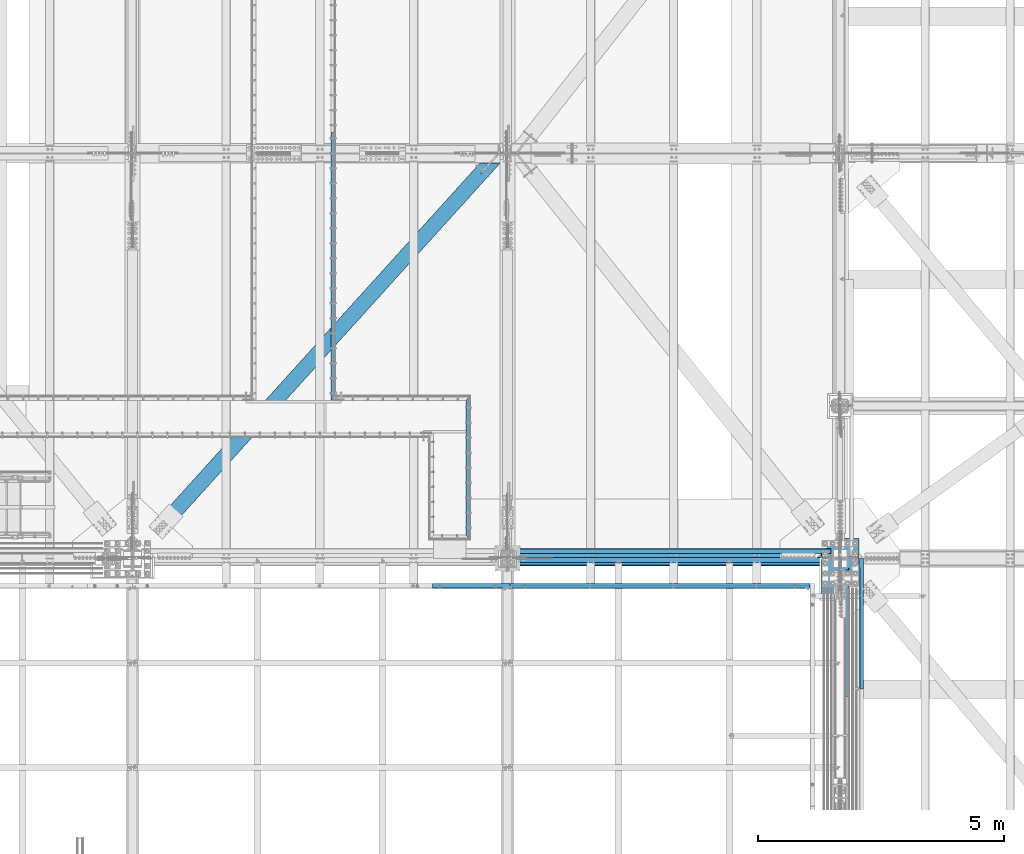
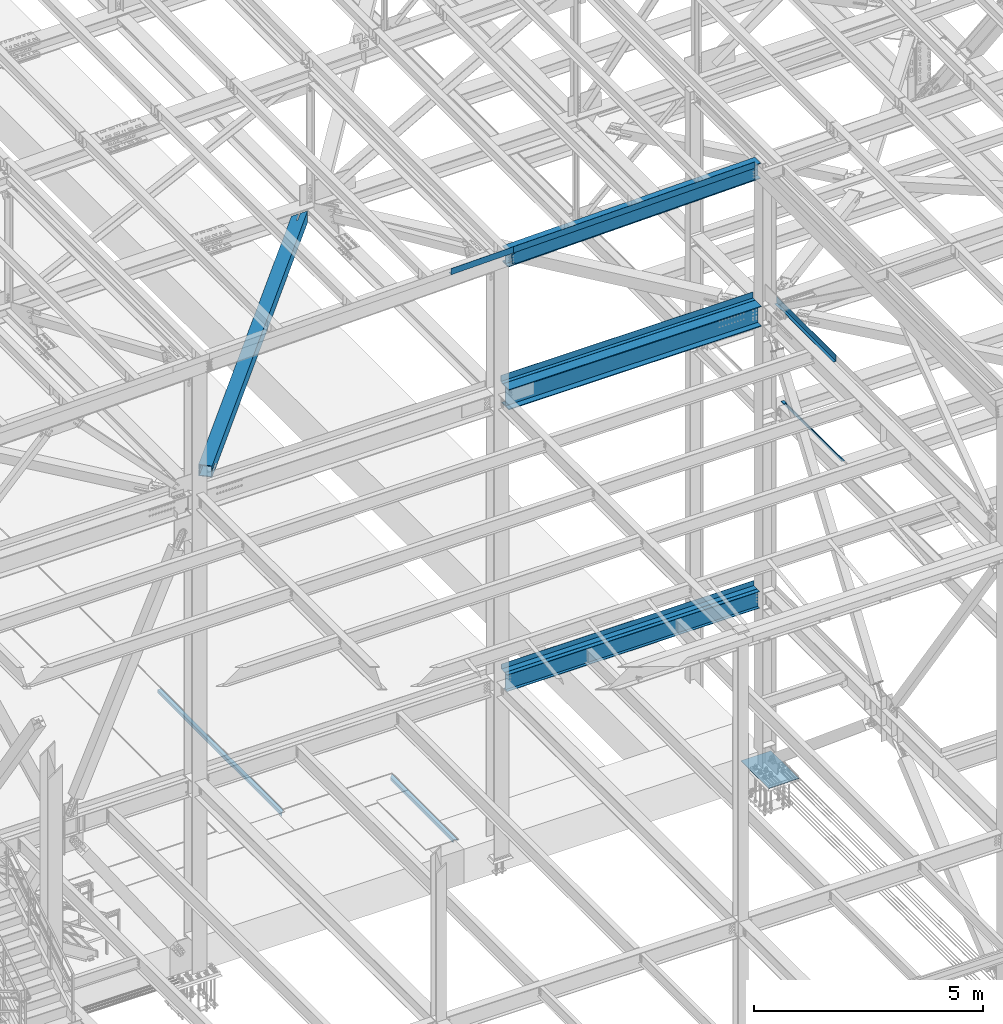
# One storey, part 1800 of 3843: 14 beams, 12 elements without a shape of their own.
"""IFC2X3 building model written with IfcOpenShell, lengths in millimetres."""

from ifc_helpers import new_model, si_unit, frame, origin_with_axes, place, context, subcontext, project, spatial, faceted_brep, material, type_object, element, aggregate, save


model = new_model("IFC2X3")

# Units and contexts
model_context = context("Model", 3, precision=1e-05, world=origin_with_axes())
body_context = subcontext(model_context, "Body", "Model", "MODEL_VIEW")
ifc_project = project(units=[si_unit("LENGTHUNIT", "METRE", prefix="MILLI"), si_unit("AREAUNIT", "SQUARE_METRE"), si_unit("VOLUMEUNIT", "CUBIC_METRE"), si_unit("MASSUNIT", "GRAM", prefix="KILO"), si_unit("TIMEUNIT", "SECOND"), si_unit("PLANEANGLEUNIT", "RADIAN"), si_unit("SOLIDANGLEUNIT", "STERADIAN"), si_unit("THERMODYNAMICTEMPERATUREUNIT", "DEGREE_CELSIUS"), si_unit("LUMINOUSINTENSITYUNIT", "LUMEN")], contexts=[model_context])

# Site, building, storey
site_placement = place(None, origin_with_axes())
site = spatial("IfcSite", under=ifc_project, at=site_placement, CompositionType="ELEMENT")
building_placement = place(site_placement, origin_with_axes())
building = spatial("IfcBuilding", under=site, at=building_placement, Name="Undefined", CompositionType="ELEMENT")
storey_placement = place(building_placement, origin_with_axes())
storey = spatial("IfcBuildingStorey", under=building, at=storey_placement, Name="Undefined", CompositionType="ELEMENT", Elevation=0.0)

# Assembly, beam
assembly_1_placement = place(storey_placement, origin_with_axes())
assembly_1 = element("IfcElementAssembly", 1, at=assembly_1_placement, inside=storey, Name="EMBED_ANGLE", AssemblyPlace="NOTDEFINED", PredefinedType="RIGID_FRAME")
ifc_material_1 = material(Name="STEEL/A36")
beam_type_1 = type_object("IfcBeamType", Name="L3-1/2X3-1/2X5/16", PredefinedType="NOTDEFINED")
beam_1_placement = place(assembly_1_placement, frame((69457.0619228334, 26000.0750033204, 30410.15), z_axis=(1.0, 0.0, 0.0), x_axis=(0.0, 1.0, 0.0)))
beam_1 = element("IfcBeam", 2, at=beam_1_placement, type_object=beam_type_1, material=ifc_material_1, Name="EMBED_ANGLE", ObjectType="L3-1/2X3-1/2X5/16", context=body_context, shape_type="Brep", body=[
    faceted_brep([(88.8999999971129, 44.4500000000007, -44.4499999999971), (-3.63797880709171e-12, 44.4499999999971, 44.4500000000007), (2917.82499712405, 44.4500000000007, 44.4499999917316), (2828.92499622636, 44.4500000000007, -44.4500000080152), (-3.63797880709171e-12, 36.5124999999971, 44.4500000000007), (2917.82499712405, 36.5125000000007, 44.4499999917316), (80.9624999971129, 36.5125000000007, -36.5124999999971), (2836.86249630651, 36.5125000000007, -36.5125000080443), (80.9624999971129, -44.4500000000007, -36.5124999999971), (2836.86249630651, -44.4500000000007, -36.5125000080443), (88.8999999971129, -44.4500000000007, -44.4499999999971), (2828.92499622636, -44.4500000000007, -44.4500000080152)], [[[0, 1, 2, 3]], [[1, 4, 5, 2]], [[4, 6, 7, 5]], [[6, 8, 9, 7]], [[8, 10, 11, 9]], [[10, 0, 3, 11]], [[5, 7, 9, 11, 3, 2]], [[10, 8, 6, 4, 1, 0]]]),
])
aggregate(assembly_1, [beam_1])

assembly_2_placement = place(storey_placement, origin_with_axes())
assembly_2 = element("IfcElementAssembly", 3, at=assembly_2_placement, inside=storey, Name="EMBED_ANGLE", AssemblyPlace="NOTDEFINED", PredefinedType="RIGID_FRAME")
beam_2_placement = place(assembly_2_placement, frame((66713.862, 34264.6001953125, 30410.15), z_axis=(0.0, 0.0, -1.0), x_axis=(0.0, -1.0, 0.0)))
beam_2 = element("IfcBeam", 4, at=beam_2_placement, type_object=beam_type_1, material=ifc_material_1, Name="EMBED_ANGLE", ObjectType="L3-1/2X3-1/2X5/16", context=body_context, shape_type="Brep", body=[
    faceted_brep([(-3.63797880709171e-12, 44.4499999999971, -44.4500000000007), (-3.63797880709171e-12, 44.4499999999971, 44.4500000000007), (5435.6001953125, 44.4499999999971, 44.4500000000007), (5435.6001953125, 44.4499999999971, -44.4500000000007), (-3.63797880709171e-12, 36.5124999999971, 44.4500000000007), (5427.6626953125, 36.5124999999971, 44.4500000000007), (-3.63797880709171e-12, 36.5124999999971, -36.5125000000007), (5427.6626953125, 36.5124999999971, -36.5125000000007), (3.63797880709171e-12, -44.4499999999971, -36.5125000000007), (5346.70019531249, -44.4499999999971, -36.5125000000007), (3.63797880709171e-12, -44.4499999999971, -44.4500000000007), (5346.70019531249, -44.4499999999971, -44.4500000000007)], [[[0, 1, 2, 3]], [[1, 4, 5, 2]], [[4, 6, 7, 5]], [[6, 8, 9, 7]], [[8, 10, 11, 9]], [[10, 0, 3, 11]], [[5, 7, 9, 11, 3, 2]], [[10, 8, 6, 4, 1, 0]]]),
])
aggregate(assembly_2, [beam_2])

# Assembly, beams
assembly_3_placement = place(storey_placement, origin_with_axes())
assembly_3 = element("IfcElementAssembly", 5, at=assembly_3_placement, inside=storey, Name="BEAM", AssemblyPlace="NOTDEFINED", PredefinedType="RIGID_FRAME")
ifc_material_2 = material(Name="STEEL/A572-50")
beam_type_2 = type_object("IfcBeamType", Name="C12X20.7", PredefinedType="NOTDEFINED")
beam_3_placement = place(assembly_3_placement, frame((70253.0420932875, 25044.4000000661, 46289.660029082), z_axis=(0.0211520550054438, 0.0, -0.999776270257025), x_axis=(0.999776270257024, 0.0, 0.0211520550054619)))
beam_3 = element("IfcBeam", 6, at=beam_3_placement, type_object=beam_type_2, material=ifc_material_2, Name="BEAM", ObjectType="C12X20.7", context=body_context, shape_type="Brep", body=[
    faceted_brep([(6142.0584947462, -38.1000000000058, 146.047460004978), (6142.0584947462, -38.1000000000058, 152.400000004971), (98.4250003414782, -38.1000000000058, 152.399999999863), (98.4250003414927, -38.1000000000058, 146.047459999871), (6142.0584947462, 38.1000000000058, 152.400000004971), (98.4250003414782, 38.1000000000058, 152.399999999863), (85.7250005323076, 30.1625000000058, 126.99999997508), (85.7250005323076, 38.1000000000058, 126.99999997508), (15.8750006201954, 38.1000000000058, 126.999999975014), (15.8753301115794, 30.1625000000058, 127.000000030457), (90.5850800503176, 30.1625000000058, 127.966729897671), (90.5850800503176, 38.1000000000058, 127.966729897671), (94.7052565184495, 30.1625000000058, 130.719743798138), (94.7052565184495, 38.1000000000058, 130.719743798138), (97.4582704189161, 30.1625000000058, 134.674927499887), (97.4582704189233, 38.1000000000058, 134.839920266269), (98.4250003414927, 1.29402906168252e-06, 139.699999784301), (98.4250003414927, 38.1000000000058, 139.699999784301), (6142.05849474619, 30.1625000000058, 134.674927505002), (6142.05849466294, 30.1624999999985, 116.299999962248), (6142.0584946629, 30.1624999999985, -114.300000034018), (6142.05849474625, 30.1625000000058, -134.674927494561), (6142.05849474623, -38.1000000000058, -146.047459994552), (6142.05849474625, -38.1000000000058, -152.399999994537), (6142.05849474625, 38.1000000000058, -152.399999994537), (98.4250003417837, -38.1000000000058, -152.399999999638), (98.4250003417837, 38.1000000000058, -152.399999999638), (94.7052565187187, 38.1000000000058, -130.719743846734), (90.5850800505723, 38.1000000000058, -127.966729946267), (85.725000532555, 38.1000000000058, -127.000000023691), (15.8750003662499, 38.1000000000058, -127.000000023749), (98.4250003417692, 38.1000000000058, -139.699999832876), (97.4582704191853, 38.1000000000058, -134.839920314858), (15.8753294955532, 30.1624999999985, -114.300001144882), (15.8753211909934, 30.1624999999985, 116.299998852854), (15.8753209642891, 30.1625000000058, -126.999999968277), (85.725000532555, 30.1625000000058, -127.000000023691), (90.5850800505723, 30.1625000000058, -127.966729946267), (94.7052565187187, 30.1625000000058, -130.719743846734), (97.458270419178, 30.1625000000058, -134.674927499669), (98.4250003417692, 1.00112811196595e-06, -139.699999832876), (98.4250003417765, -38.1000000000058, -146.047459999652)], [[[0, 1, 2, 3]], [[1, 4, 5, 2]], [[6, 7, 8, 9]], [[10, 11, 7, 6]], [[12, 13, 11, 10]], [[14, 15, 13, 12]], [[16, 17, 15, 14]], [[2, 5, 17, 16, 3]], [[14, 18, 0, 3, 16]], [[1, 0, 18, 19, 20, 21, 22, 23, 24, 4]], [[24, 23, 25, 26]], [[27, 28, 29, 30, 8, 7, 11, 13, 15, 17, 5, 4, 24, 26, 31, 32]], [[33, 34, 9, 8, 30, 35]], [[21, 20, 19, 18, 14, 12, 10, 6, 9, 34, 33, 35, 36, 37, 38, 39]], [[22, 21, 39, 40, 41]], [[23, 22, 41, 25]], [[40, 31, 26, 25, 41]], [[39, 32, 31, 40]], [[38, 27, 32, 39]], [[37, 28, 27, 38]], [[36, 29, 28, 37]], [[35, 30, 29, 36]]]),
])
beam_type_3 = type_object("IfcBeamType", PredefinedType="NOTDEFINED")
beam_4_placement = place(assembly_3_placement, frame((73356.2395281099, 25107.8999997327, 46510.9236615388), z_axis=(0.999776270257024, 0.0, 0.0211520550054619), x_axis=(0.0, -1.0, 0.0)))
beam_4 = element("IfcBeam", 7, at=beam_4_placement, type_object=beam_type_3, material=ifc_material_1, Name="BENT_PLATE", context=body_context, shape_type="Brep", body=[
    faceted_brep([(-3.50355549016967e-07, -3.17499999742722, -3048.00000001723), (3.50421032635495e-07, -3.17500000260043, 3048.00000001724), (3.5035191103816e-07, 3.17499999739084, 3048.00000001724), (-3.50424670614302e-07, 3.17500000256405, -3048.00000001723), (101.599999864371, 3.17499999856227, 3048.00000000522), (101.599998739839, 3.17500000373548, -3048.00000002925), (95.249998765099, -3.17499999632128, -3048.00000002851), (95.2499998896274, -3.17500000149448, 3048.00000000597), (101.600000309205, -161.925000875126, 3047.9999999938), (101.599999608374, -161.925000446165, -3048.00000004067), (95.2500003092064, -161.925000900388, 3047.99999999456), (95.2499996083752, -161.925000471427, -3048.00000003992)], [[[0, 1, 2, 3]], [[3, 2, 4, 5]], [[1, 0, 6, 7]], [[5, 4, 8, 9]], [[4, 2, 1, 7, 10, 8]], [[7, 6, 11, 10]], [[6, 0, 3, 5, 9, 11]], [[10, 11, 9, 8]]]),
])
aggregate(assembly_3, [beam_3, beam_4])

# Assembly, beam
assembly_4_placement = place(storey_placement, origin_with_axes())
assembly_4 = element("IfcElementAssembly", 8, at=assembly_4_placement, inside=storey, Name="BEAM", AssemblyPlace="NOTDEFINED", PredefinedType="RIGID_FRAME")
beam_5_placement = place(assembly_4_placement, frame((69520.1104824226, 25107.8999985199, 46429.7633261585), z_axis=(0.999776270257024, 0.0, 0.0211520550054619), x_axis=(0.0, -1.0, 0.0)))
beam_5 = element("IfcBeam", 9, at=beam_5_placement, type_object=beam_type_3, material=ifc_material_1, Name="BENT_PLATE", context=body_context, shape_type="Brep", body=[
    faceted_brep([(1.80807546712458e-09, 2.85952410195023e-06, 788.98750000447), (1.83717929758132e-09, -3.17500000066502, 785.81249736427), (95.2499986975417, -3.17499999957363, 785.812497363717), (98.4249975161692, 2.86066642729566e-06, 788.987500003917), (95.2499993281599, -161.925001317926, 785.81249745957), (98.4249981594003, -161.925001305302, 788.987500003583), (-1.77533365786076e-09, -3.1749999993408, -785.812500061627), (-1.81535142473876e-09, -5.62722561880946e-08, -788.987500004456), (98.4249986264876, -5.5137206800282e-08, -788.987500005023), (95.2499986923067, -3.17499999824213, -785.812500062151), (98.424999271374, -161.925001302356, -788.987500005343), (95.2499993245401, -161.925001314979, -785.812500062311), (1.77533365786076e-09, 3.17499999931897, 788.987500004485), (-1.84809323400259e-09, 3.17500000065047, -788.987500004456), (101.599998672296, 3.17500000048312, 788.987500003903), (101.599998667039, 3.17500000182918, -788.987500005023), (101.599999328169, -161.925001292671, 788.987500003583), (101.599999324535, -161.925001289717, -788.987500005358)], [[[0, 1, 2, 3]], [[3, 2, 4, 5]], [[6, 7, 8, 9]], [[9, 8, 10, 11]], [[9, 11, 4, 2]], [[1, 0, 12, 13, 7, 6]], [[13, 12, 14, 15]], [[2, 1, 6, 9]], [[15, 14, 16, 17]], [[16, 14, 12, 0, 3, 5]], [[7, 13, 15, 17, 10, 8]], [[11, 10, 17, 16, 5, 4]]]),
])
aggregate(assembly_4, [beam_5])

assembly_5_placement = place(storey_placement, origin_with_axes())
assembly_5 = element("IfcElementAssembly", 10, at=assembly_5_placement, inside=storey, Name="BEAM", AssemblyPlace="NOTDEFINED", PredefinedType="RIGID_FRAME")
ifc_material_3 = material(Name="STEEL/A992")
beam_type_4 = type_object("IfcBeamType", Name="W21X101", PredefinedType="NOTDEFINED")
beam_6_placement = place(assembly_5_placement, frame((70256.4, 25615.9, 42197.3375), z_axis=(0.0, 0.0, 1.0), x_axis=(1.0, 0.0, 0.0)))
beam_6 = element("IfcBeam", 11, at=beam_6_placement, type_object=beam_type_4, material=ifc_material_3, Name="BEAM", ObjectType="W21X101", context=body_context, shape_type="Brep", body=[
    faceted_brep([(196.850000000006, -155.575000000001, -271.462500000001), (196.850000000006, 155.575000000001, -271.462500000001), (6565.89999999999, 155.575000000001, -271.462500000001), (6565.89999999999, -155.575000000001, -271.462500000001), (196.850000000006, -155.575000000001, -250.824999999997), (196.850000000006, -6.34999999999854, -250.824999999997), (196.850000000006, -6.34999999999854, 250.824999999997), (196.850000000006, -155.575000000001, 250.824999999997), (196.850000000006, -155.575000000001, 271.462500000001), (196.850000000006, 155.575000000001, 271.462500000001), (196.850000000006, 155.575000000001, 250.824999999997), (196.850000000006, 6.34999999999854, 250.824999999997), (196.850000000006, 6.34999999999854, -250.824999999997), (196.850000000006, 155.575000000001, -250.824999999997), (6565.89999999999, -155.575000000001, -250.824999999997), (6565.89999999999, -6.34999999999854, -250.824999999997), (6565.89999999999, -6.34999999999854, 250.824999999997), (6565.89999999999, -155.575000000001, 250.824999999997), (6565.89999999999, -155.575000000001, 271.462500000001), (6565.89999999999, 155.575000000001, 271.462500000001), (6565.89999999999, 155.575000000001, 250.824999999997), (6565.89999999999, 6.34999999999854, 250.824999999997), (6565.89999999999, 6.34999999999854, -250.824999999997), (6565.89999999999, 155.575000000001, -250.824999999997)], [[[0, 1, 2, 3]], [[0, 4, 5, 6, 7, 8, 9, 10, 11, 12, 13, 1]], [[5, 4, 14, 15]], [[6, 5, 15, 16]], [[7, 6, 16, 17]], [[8, 7, 17, 18]], [[9, 8, 18, 19]], [[10, 9, 19, 20]], [[11, 10, 20, 21]], [[12, 11, 21, 22]], [[13, 12, 22, 23]], [[1, 13, 23, 2]], [[22, 21, 20, 19, 18, 17, 16, 15, 14, 3, 2, 23]], [[4, 0, 3, 14]]]),
])
aggregate(assembly_5, [beam_6])

assembly_6_placement = place(storey_placement, origin_with_axes())
assembly_6 = element("IfcElementAssembly", 12, at=assembly_6_placement, inside=storey, Name="BENT_PLATE", AssemblyPlace="NOTDEFINED", PredefinedType="RIGID_FRAME")
beam_type_5 = type_object("IfcBeamType", PredefinedType="NOTDEFINED")
beam_7_placement = place(assembly_6_placement, frame((77117.5749999996, 24118.094, 42471.975), z_axis=(0.0, -1.0, 0.0), x_axis=(1.0, 0.0, 0.0)))
beam_7 = element("IfcBeam", 13, at=beam_7_placement, type_object=beam_type_5, material=ifc_material_1, Name="BENT_PLATE", context=body_context, shape_type="Brep", body=[
    faceted_brep([(0.0, 3.17500000000291, 1300.95650004768), (0.0, 4.7679350245744e-08, 1304.1315), (69.8499999527558, 4.76647983305156e-08, 1304.1315), (66.6750000004104, 3.17499999998836, 1300.95650004768), (69.8499999527558, 161.924999999545, 1304.1315), (66.6750000004104, 161.924999999545, 1300.95650004768), (66.6750000004104, 161.924999999545, -1304.1315), (66.6750000004104, 3.17499999998836, -1304.1315), (66.6750000004104, 3.17499999998836, -1266.81639935417), (66.675000000454, -3.17500000001746, -1266.81639935417), (66.6750000004686, -3.17500000001746, -1304.1315), (0.0, -3.17500000000291, -1266.81639935416), (0.0, 3.17500000000291, -1266.81639935416), (9.52499997131235, -3.17500000000291, -990.599750006706), (9.52499997131235, 3.17499999999563, -990.599750006706), (0.0, 3.17500000000291, -990.599750003017), (0.0, -3.17500000000291, -990.599750003017), (9.5249999712978, -3.17500000000291, -673.099750006717), (9.5249999712978, 3.17499999999563, -673.099750006717), (0.0, -3.17500000000291, -673.099750006702), (0.0, 3.17500000000291, -673.099750006702), (0.0, -3.17500000000291, 1304.1315), (73.0250000004162, -3.17500000001746, 1304.1315), (73.0250000004162, 161.924999999545, 1304.1315), (73.0250000004162, -3.17500000001746, -1304.1315), (73.0250000004162, 161.924999999545, -1304.1315)], [[[0, 1, 2, 3]], [[3, 2, 4, 5]], [[6, 7, 8, 3, 5]], [[9, 8, 7, 10]], [[11, 12, 8, 9]], [[13, 14, 15, 16]], [[17, 18, 14, 13]], [[19, 20, 18, 17]], [[20, 19, 21, 1, 0]], [[1, 21, 22, 23, 4, 2]], [[22, 24, 25, 23]], [[6, 25, 24, 10, 7]], [[23, 25, 6, 5, 4]], [[8, 12, 15, 14, 18, 20, 0, 3]], [[16, 15, 12, 11]], [[24, 22, 21, 19, 17, 13, 16, 11, 9, 10]]]),
])
aggregate(assembly_6, [beam_7])

assembly_7_placement = place(storey_placement, origin_with_axes())
assembly_7 = element("IfcElementAssembly", 14, at=assembly_7_placement, inside=storey, Name="BENT_PLATE", AssemblyPlace="NOTDEFINED", PredefinedType="RIGID_FRAME")
beam_type_6 = type_object("IfcBeamType", PredefinedType="NOTDEFINED")
beam_8_placement = place(assembly_7_placement, frame((77484.2875000011, 24288.75, 39627.1750000005), z_axis=(0.0, 1.0, 0.0), x_axis=(-1.0, 0.0, 0.0)))
beam_8 = element("IfcBeam", 15, at=beam_8_placement, type_object=beam_type_6, material=ifc_material_1, Name="BENT_PLATE", context=body_context, shape_type="Brep", body=[
    faceted_brep([(73.0249999527732, -4.71118255518377e-08, -1327.15), (69.8500000010245, 3.17499999969004, -1323.97499999999), (69.8500000012136, 73.024999998619, -1323.97499999999), (73.025000001202, 73.0249999986117, -1327.15), (0.0, -4.74465196020901e-08, -1327.15), (1.45519152283669e-11, 3.17500000000291, -1323.97499999999), (1.45519152283669e-11, -3.17500000000291, 1327.15), (-1.45519152283669e-11, -3.17500000000291, -1327.15), (76.2000000010157, -3.17500000034488, -1327.15), (76.1999999999825, -3.1749999997628, 1327.14999999999), (-1.45519152283669e-11, 3.17500000000291, 1327.15), (76.1999999999243, 3.17500000035216, 1327.15), (69.8500000010245, 3.17499999969004, 1327.15), (76.2000000012195, 73.0249999986045, 1143.0), (69.8500000012136, 73.024999998619, 1143.0), (69.8500000010245, 3.17499999969004, 1143.0), (76.2000000010303, 3.17499999977008, 1143.0), (76.2000000012195, 73.0249999986045, -1327.15), (1.45519152283669e-11, 3.17499999999927, 1143.00000000001)], [[[0, 1, 2, 3]], [[4, 5, 1, 0]], [[6, 7, 8, 9]], [[10, 6, 9, 11, 12]], [[13, 14, 15, 16]], [[11, 16, 15, 12]], [[9, 8, 17, 13, 16, 11]], [[14, 13, 17, 3, 2]], [[15, 14, 2, 1]], [[18, 10, 12, 15, 1, 5]], [[7, 6, 10, 18, 5, 4]], [[17, 8, 7, 4, 0, 3]]]),
])
aggregate(assembly_7, [beam_8])

assembly_8_placement = place(storey_placement, origin_with_axes())
assembly_8 = element("IfcElementAssembly", 16, at=assembly_8_placement, inside=storey, Name="BENT_PLATE", AssemblyPlace="NOTDEFINED", PredefinedType="RIGID_FRAME")
beam_type_7 = type_object("IfcBeamType", PredefinedType="NOTDEFINED")
beam_9_placement = place(assembly_8_placement, frame((73637.775, 25720.6749999981, 42471.975), z_axis=(-1.0, 0.0, 0.0), x_axis=(0.0, 1.0, 0.0)))
beam_9 = element("IfcBeam", 17, at=beam_9_placement, type_object=beam_type_7, material=ifc_material_1, Name="BENT_PLATE", context=body_context, shape_type="Brep", body=[
    faceted_brep([(0.0, -3.17500000000291, -3184.52499999999), (0.0, -3.17500000000291, 3184.52499999999), (0.0, 3.17500000000291, 3184.52499999999), (0.0, 3.17500000000291, -3184.52499999999), (98.4250000018801, 3.17500000000291, 3184.52499999999), (98.4250000018801, 3.17500000000291, -3184.52499999999), (92.0750000018816, -3.17500000000291, -3184.52499999999), (92.0750000018816, -3.17500000000291, 3184.52499999999), (98.4250000018801, -161.924999998111, 3184.52499999999), (98.4250000018801, -161.924999998111, -3184.52499999999), (92.0750000018816, -161.924999998111, 3184.52499999999), (92.0750000018816, -161.924999998111, -3184.52499999999)], [[[0, 1, 2, 3]], [[3, 2, 4, 5]], [[1, 0, 6, 7]], [[5, 4, 8, 9]], [[4, 2, 1, 7, 10, 8]], [[7, 6, 11, 10]], [[6, 0, 3, 5, 9, 11]], [[10, 11, 9, 8]]]),
])
aggregate(assembly_8, [beam_9])

# Assembly, beams
assembly_9_placement = place(storey_placement, origin_with_axes())
assembly_9 = element("IfcElementAssembly", 18, at=assembly_9_placement, inside=storey, Name="BEAM", AssemblyPlace="NOTDEFINED", PredefinedType="RIGID_FRAME")
beam_type_8 = type_object("IfcBeamType", PredefinedType="NOTDEFINED")
beam_10_placement = place(assembly_9_placement, frame((73637.775, 25641.3, 34813.875), z_axis=(-1.0, 0.0, 0.0), x_axis=(0.0, 1.0, 0.0)))
beam_10 = element("IfcBeam", 19, at=beam_10_placement, type_object=beam_type_8, material=ifc_material_1, Name="BENT_PLATE", context=body_context, shape_type="Brep", body=[
    faceted_brep([(0.0, -3.17500000000291, -3184.52499999999), (0.0, -3.17500000000291, 3184.52499999999), (0.0, 3.17500000000291, 3184.52499999999), (0.0, 3.17500000000291, -3184.52499999999), (152.399999999994, 3.17500000000291, 3184.52499999999), (152.399999999994, 3.17500000000291, -3184.52499999999), (146.049999999996, -3.17500000000291, -3184.52499999999), (146.049999999996, -3.17500000000291, 3184.52499999999), (152.399999999994, -136.524999999994, 3184.52499999999), (152.399999999994, -136.524999999994, -3184.52499999999), (146.049999999996, -136.524999999994, 3184.52499999999), (146.049999999996, -136.524999999994, -3184.52499999999)], [[[0, 1, 2, 3]], [[3, 2, 4, 5]], [[1, 0, 6, 7]], [[5, 4, 8, 9]], [[4, 2, 1, 7, 10, 8]], [[7, 6, 11, 10]], [[6, 0, 3, 5, 9, 11]], [[10, 11, 9, 8]]]),
])
beam_type_9 = type_object("IfcBeamType", Name="W18X35", PredefinedType="NOTDEFINED")
beam_11_placement = place(assembly_9_placement, frame((70256.4, 25615.9, 34585.275), z_axis=(0.0, 0.0, 1.0), x_axis=(1.0, 0.0, 0.0)))
beam_11 = element("IfcBeam", 20, at=beam_11_placement, type_object=beam_type_9, material=ifc_material_3, Name="BEAM", ObjectType="W18X35", context=body_context, shape_type="Brep", body=[
    faceted_brep([(196.849999999999, -76.2000000000007, -214.3125), (196.849999999999, -76.2000000000007, -225.424999999999), (6565.89999999999, -76.2000000000007, -225.425000000003), (6565.90000000001, -76.1999999999971, -214.3125), (196.849999999999, -3.96875, -214.3125), (6565.90000000001, -3.96875, -214.3125), (196.849999999999, -3.96875, 214.3125), (6565.90000000001, -3.96875, 214.3125), (196.849999999999, -76.2000000000007, 214.3125), (6565.90000000001, -76.1999999999971, 214.3125), (196.849999999999, -76.2000000000007, 225.425000000003), (6565.89999999999, -76.2000000000007, 225.425000000003), (196.849999999999, 76.2000000000007, 225.425000000003), (6565.89999999999, 76.2000000000007, 225.425000000003), (196.849999999999, 76.2000000000007, 214.3125), (6565.90000000001, 76.1999999999971, 214.3125), (196.849999999999, 3.96875, 214.3125), (6565.90000000001, 3.96875, 214.3125), (196.849999999999, 3.96875, -214.3125), (6565.90000000001, 3.96875, -214.3125), (196.849999999999, 76.2000000000007, -214.3125), (6565.90000000001, 76.1999999999971, -214.3125), (196.849999999999, 76.2000000000007, -225.424999999999), (6565.89999999999, 76.2000000000007, -225.425000000003)], [[[0, 1, 2, 3]], [[4, 0, 3, 5]], [[6, 4, 5, 7]], [[8, 6, 7, 9]], [[10, 8, 9, 11]], [[12, 10, 11, 13]], [[14, 12, 13, 15]], [[16, 14, 15, 17]], [[18, 16, 17, 19]], [[20, 18, 19, 21]], [[1, 0, 4, 6, 8, 10, 12, 14, 16, 18, 20, 22]], [[1, 22, 23, 2]], [[19, 17, 15, 13, 11, 9, 7, 5, 3, 2, 23, 21]], [[22, 20, 21, 23]]]),
])
aggregate(assembly_9, [beam_10, beam_11])

# Assembly, beam
assembly_10_placement = place(storey_placement, origin_with_axes())
assembly_10 = element("IfcElementAssembly", 21, at=assembly_10_placement, inside=storey, AssemblyPlace="NOTDEFINED", PredefinedType="RIGID_FRAME")
ifc_material_4 = material()
beam_type_10 = type_object("IfcBeamType", Name="HSS12X12X3/4", PredefinedType="NOTDEFINED")
beam_12_placement = place(assembly_10_placement, frame((62636.4000000252, 25615.8999999988, 42246.55), z_axis=(0.74169845569379, -0.670733479723091, 0.0), x_axis=(0.670733509108473, 0.741698429119972, 0.0)))
beam_12 = element("IfcBeam", 22, at=beam_12_placement, type_object=beam_type_10, material=ifc_material_4, ObjectType="HSS12X12X3/4", context=body_context, shape_type="Brep", body=[
    faceted_brep([(1323.47584071972, -1.58750000000146, -133.349999999242), (1323.47584071983, -1.58750000000146, -152.399999999223), (1020.26334108781, -1.58750000000146, -152.399999999372), (1020.26334108776, -1.58750000000146, -133.349999999384), (1328.94343040565, -0.499928791716229, -133.349999999238), (1328.94343040576, -0.499928791716229, -152.399999999219), (1333.57862912572, 2.59721197552426, -133.349999999235), (1333.57862912582, 2.59721197552426, -152.399999999219), (1336.67576989298, 7.23241069557116, -133.349999999227), (1336.67576989309, 7.23241069557116, -152.399999999216), (1337.76334110127, 12.6999996185259, -133.349999999224), (1337.76334110137, 12.6999996185259, -152.399999999212), (1336.67576989298, 18.167589304423, -133.349999999227), (1336.67576989309, 18.167589304423, -152.399999999216), (1333.57862912572, 22.8027880244699, -133.349999999235), (1333.57862912582, 22.8027880244699, -152.399999999219), (1328.94343040565, 25.8999287917104, -133.349999999238), (1328.94343040576, 25.8999287917104, -152.399999999219), (1323.47584071972, 26.9874999999956, -133.349999999242), (1323.47584071983, 26.9874999999956, -152.399999999223), (1020.26334108776, 26.9874999999956, -133.349999999384), (1020.26334108781, 26.9874999999956, -152.399999999372), (1020.26334108781, -152.400000000001, -152.399999999372), (1020.26334108781, 152.400000000001, -152.399999999372), (10690.2510809812, 152.400000000001, -152.39999999453), (10690.2510809812, -152.400000000001, -152.39999999453), (10557.2690304638, 133.349999999999, 13.1999348631907), (10557.2690304638, 152.400000000001, 13.1999348631907), (10562.7366201344, 152.400000000001, 14.2875060901388), (10562.7366201344, 133.349999999999, 14.2875060901388), (10552.6338317626, 133.349999999999, 10.102794088365), (10552.6338317626, 152.400000000001, 10.102794088365), (10549.5366910119, 133.349999999999, 5.46759537104663), (10549.5366910119, 152.400000000001, 5.46759537104663), (10548.4491198133, 133.349999999999, 6.46679836791009e-06), (10548.4491198133, 152.400000000001, 6.46679836791009e-06), (10549.5366910314, 133.349999999999, -5.46758322883397), (10549.5366910314, 152.400000000001, -5.46758322883397), (10552.6338318152, 133.349999999999, -10.1027819516094), (10552.6338318152, 152.400000000001, -10.1027819516094), (10557.2690305541, 133.349999999999, -13.1999227112901), (10557.2690305541, 152.400000000001, -13.1999227112901), (10562.7366202554, 133.349999999999, -14.2874939009052), (10562.7366202554, 152.400000000001, -14.2874939009052), (10815.1491198144, 133.349999999999, -14.2874928335914), (10815.1491198144, 152.400000000001, -14.2874928335914), (10557.2690304638, -152.400000000001, 13.1999348631907), (10557.2690304638, -133.349999999999, 13.1999348631907), (10562.7366201344, -133.349999999999, 14.2875060901388), (10562.7366201344, -152.400000000001, 14.2875060901388), (10552.6338317626, -152.400000000001, 10.102794088365), (10552.6338317626, -133.349999999999, 10.102794088365), (10549.5366910119, -152.400000000001, 5.46759537104663), (10549.5366910119, -133.349999999999, 5.46759537104663), (10548.4491198133, -152.400000000001, 6.46679836791009e-06), (10548.4491198133, -133.349999999999, 6.46679836791009e-06), (10549.5366910314, -152.400000000001, -5.46758322883397), (10549.5366910314, -133.349999999999, -5.46758322883397), (10552.6338318152, -152.400000000001, -10.1027819516094), (10552.6338318152, -133.349999999999, -10.1027819516094), (10557.2690305541, -152.400000000001, -13.1999227112901), (10557.2690305541, -133.349999999999, -13.1999227112901), (10562.7366202554, -152.400000000001, -14.2874939009052), (10562.7366202554, -133.349999999999, -14.2874939009052), (10815.1491198144, -152.400000000001, -14.2874928335914), (10815.1491198144, -133.349999999999, -14.2874928335914), (10707.4783957891, 133.349999999999, -133.349999994531), (10707.4783957891, -133.349999999999, -133.349999994531), (1020.26334108776, 133.349999999999, -133.349999999384), (1020.26334108776, -133.349999999999, -133.349999999384), (1020.26334108706, 152.400000000001, 152.400000000383), (1020.26334108711, 133.349999999999, 133.350000000395), (1020.26334108711, 26.9874999999956, 133.350000000395), (1020.26334108706, 26.9874999999956, 152.400000000383), (1323.47584071828, 26.9874999999956, 133.350000000548), (1323.47584071819, 26.9874999999956, 152.400000000536), (1328.94343040422, 25.8999287917104, 133.350000000548), (1328.94343040411, 25.8999287917104, 152.400000000536), (1333.57862912428, 22.8027880244699, 133.350000000548), (1333.57862912418, 22.8027880244699, 152.400000000536), (1336.67576989155, 18.167589304423, 133.350000000562), (1336.67576989145, 18.167589304423, 152.40000000054), (1337.76334109984, 12.6999996185259, 133.350000000559), (1337.76334109974, 12.6999996185259, 152.400000000547), (1336.67576989155, 7.23241069557116, 133.350000000562), (1336.67576989145, 7.23241069557116, 152.40000000054), (1333.57862912428, 2.59721197552426, 133.350000000548), (1333.57862912418, 2.59721197552426, 152.400000000536), (1328.94343040422, -0.499928791716229, 133.350000000548), (1328.94343040411, -0.499928791716229, 152.400000000536), (1323.47584071828, -1.58750000000146, 133.350000000548), (1323.47584071819, -1.58750000000146, 152.400000000536), (1020.26334108711, -1.58750000000146, 133.350000000395), (1020.26334108706, -1.58750000000146, 152.400000000383), (1020.26334108711, -133.349999999999, 133.350000000395), (1020.26334108706, -152.400000000001, 152.400000000383), (10965.8881179079, -152.400000000001, 152.400000005371), (10965.8881179079, 152.400000000001, 152.400000005371), (10840.9900921176, 152.400000000001, 14.2875072673232), (10840.9900921176, 133.349999999999, 14.2875072673232), (10948.6608031, 133.349999999999, 133.350000005375), (10948.6608031, -133.349999999999, 133.350000005375), (10840.9900921176, -133.349999999999, 14.2875072673232), (10840.9900921176, -152.400000000001, 14.2875072673232)], [[[0, 1, 2, 3]], [[4, 5, 1, 0]], [[6, 7, 5, 4]], [[8, 9, 7, 6]], [[10, 11, 9, 8]], [[12, 13, 11, 10]], [[14, 15, 13, 12]], [[16, 17, 15, 14]], [[18, 19, 17, 16]], [[20, 21, 19, 18]], [[22, 2, 1, 5, 7, 9, 11, 13, 15, 17, 19, 21, 23, 24, 25]], [[26, 27, 28, 29]], [[30, 31, 27, 26]], [[32, 33, 31, 30]], [[34, 35, 33, 32]], [[36, 37, 35, 34]], [[38, 39, 37, 36]], [[40, 41, 39, 38]], [[42, 43, 41, 40]], [[43, 42, 44, 45]], [[46, 47, 48, 49]], [[50, 51, 47, 46]], [[52, 53, 51, 50]], [[54, 55, 53, 52]], [[56, 57, 55, 54]], [[58, 59, 57, 56]], [[60, 61, 59, 58]], [[62, 63, 61, 60]], [[63, 62, 64, 65]], [[24, 45, 44, 66, 67, 65, 64, 25]], [[68, 20, 18, 16, 14, 12, 10, 8, 6, 4, 0, 3, 69, 67, 66]], [[70, 23, 21, 20, 68, 71, 72, 73]], [[73, 72, 74, 75]], [[75, 74, 76, 77]], [[77, 76, 78, 79]], [[79, 78, 80, 81]], [[81, 80, 82, 83]], [[83, 82, 84, 85]], [[85, 84, 86, 87]], [[87, 86, 88, 89]], [[89, 88, 90, 91]], [[91, 90, 92, 93]], [[94, 69, 3, 2, 22, 95, 93, 92]], [[70, 73, 75, 77, 79, 81, 83, 85, 87, 89, 91, 93, 95, 96, 97]], [[28, 27, 31, 33, 35, 37, 39, 41, 43, 45, 24, 23, 70, 97, 98]], [[29, 28, 98, 99]], [[71, 68, 66, 44, 42, 40, 38, 36, 34, 32, 30, 26, 29, 99, 100]], [[94, 92, 90, 88, 86, 84, 82, 80, 78, 76, 74, 72, 71, 100, 101]], [[48, 47, 51, 53, 55, 57, 59, 61, 63, 65, 67, 69, 94, 101, 102]], [[49, 48, 102, 103]], [[95, 22, 25, 64, 62, 60, 58, 56, 54, 52, 50, 46, 49, 103, 96]], [[102, 101, 100, 99, 98, 97, 96, 103]]]),
])
aggregate(assembly_10, [beam_12])

assembly_11_placement = place(storey_placement, origin_with_axes())
assembly_11 = element("IfcElementAssembly", 23, at=assembly_11_placement, inside=storey, Name="BEAM", AssemblyPlace="NOTDEFINED", PredefinedType="RIGID_FRAME")
beam_type_11 = type_object("IfcBeamType", Name="W16X67", PredefinedType="NOTDEFINED")
beam_13_placement = place(assembly_11_placement, frame((70260.7988428104, 25615.9, 45923.0295881778), z_axis=(-0.0211520980073474, 0.0, 0.999776269347241), x_axis=(0.999776270257024, 0.0, 0.0211520550054619)))
beam_13 = element("IfcBeam", 24, at=beam_13_placement, type_object=beam_type_11, material=ifc_material_3, Name="BEAM", ObjectType="W16X67", context=body_context, shape_type="Brep", body=[
    faceted_brep([(188.094396478875, -130.174999999999, -207.962499999492), (188.094396478875, 130.174999999999, -207.962499999492), (6558.56966715485, 130.174999999999, -207.962499994101), (6558.56966715485, -130.174999999999, -207.962499994101), (188.463847647872, -130.174999999999, -190.49999999952), (188.463847647872, -4.76250000000073, -190.49999999952), (196.524600426201, -4.76250000000073, 190.499999999869), (196.524600426201, -130.174999999999, 190.499999999869), (196.894051595213, -130.174999999999, 207.962499999841), (196.894051595213, 130.174999999999, 207.962499999841), (196.524600426201, 130.174999999999, 190.499999999869), (196.524600426201, 4.76250000000073, 190.499999999869), (195.989385299312, 4.76250000000073, 165.202490022384), (189.242289076908, 4.76250000000073, -153.706144372954), (188.463847647872, 4.76250000000073, -190.49999999952), (188.463847647872, 130.174999999999, -190.49999999952), (6558.93911832385, -130.174999999999, -190.499999994128), (6558.93911832385, -4.76250000000073, -190.499999994128), (6566.99987110219, -4.76250000000073, 190.500000005261), (6566.99987110219, -130.174999999999, 190.500000005261), (6567.3693222712, -130.174999999999, 207.962500005233), (6567.3693222712, 130.174999999999, 207.962500005233), (6566.99987110219, 130.174999999999, 190.500000005261), (6566.99987110219, 4.76250000000073, 190.500000005261), (6558.93911832385, 4.76250000000073, -190.499999994128), (6558.93911832385, 130.174999999999, -190.499999994128)], [[[0, 1, 2, 3]], [[0, 4, 5, 6, 7, 8, 9, 10, 11, 12, 13, 14, 15, 1]], [[5, 4, 16, 17]], [[6, 5, 17, 18]], [[7, 6, 18, 19]], [[8, 7, 19, 20]], [[9, 8, 20, 21]], [[10, 9, 21, 22]], [[11, 10, 22, 23]], [[14, 13, 12, 11, 23, 24]], [[15, 14, 24, 25]], [[1, 15, 25, 2]], [[24, 23, 22, 21, 20, 19, 18, 17, 16, 3, 2, 25]], [[4, 0, 3, 16]]]),
])
aggregate(assembly_11, [beam_13])

assembly_12_placement = place(storey_placement, origin_with_axes())
assembly_12 = element("IfcElementAssembly", 25, at=assembly_12_placement, inside=storey, Name="TEMPLATE", AssemblyPlace="NOTDEFINED", PredefinedType="RIGID_FRAME")
beam_type_12 = type_object("IfcBeamType", PredefinedType="NOTDEFINED")
beam_14_placement = place(assembly_12_placement, frame((77393.7999969482, 25412.7, 30065.6625), z_axis=(0.0, -1.0, 0.0), x_axis=(-1.0, 0.0, 0.0)))
beam_14 = element("IfcBeam", 26, at=beam_14_placement, type_object=beam_type_12, material=ifc_material_2, Name="TEMPLATE", context=body_context, shape_type="Brep", body=[
    faceted_brep([(0.0, 4.76250000000073, -609.599999999999), (0.0, 4.76250000000073, 609.599999999999), (762.00001220702, 4.76250000000073, 609.599999999999), (762.00001220702, 4.76250000000073, -609.599999999999), (0.0, -4.76250000000073, 609.599999999999), (762.00001220702, -4.76250000000073, 609.599999999999), (0.0, -4.76250000000073, -609.599999999999), (762.00001220702, -4.76250000000073, -609.599999999999)], [[[0, 1, 2, 3]], [[1, 4, 5, 2]], [[4, 6, 7, 5]], [[6, 0, 3, 7]], [[5, 7, 3, 2]], [[6, 4, 1, 0]]]),
])
aggregate(assembly_12, [beam_14])

save(model, "model.ifc")
